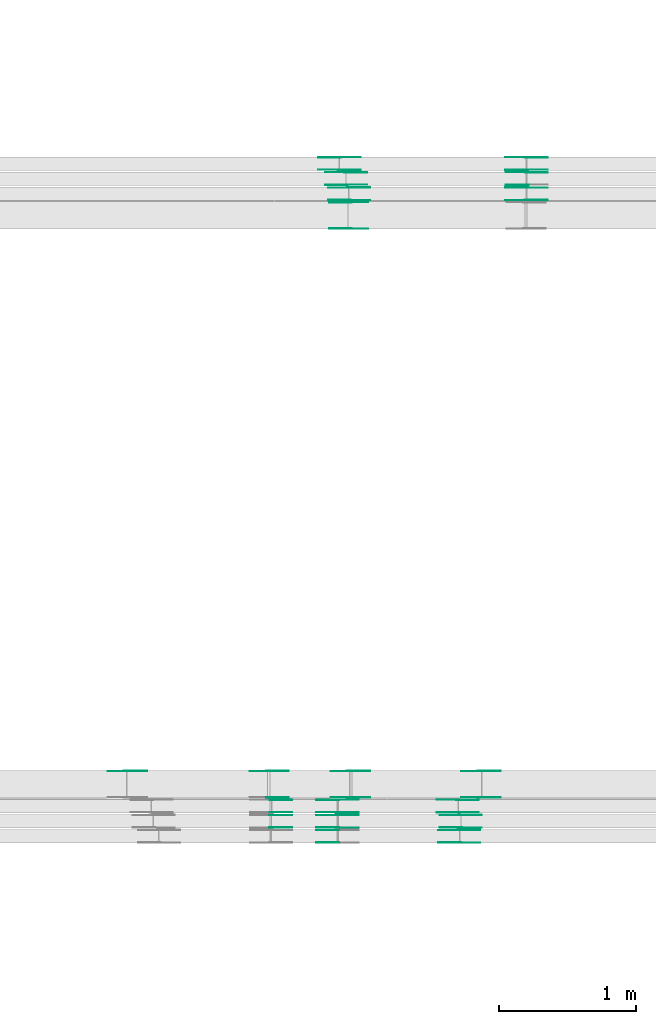
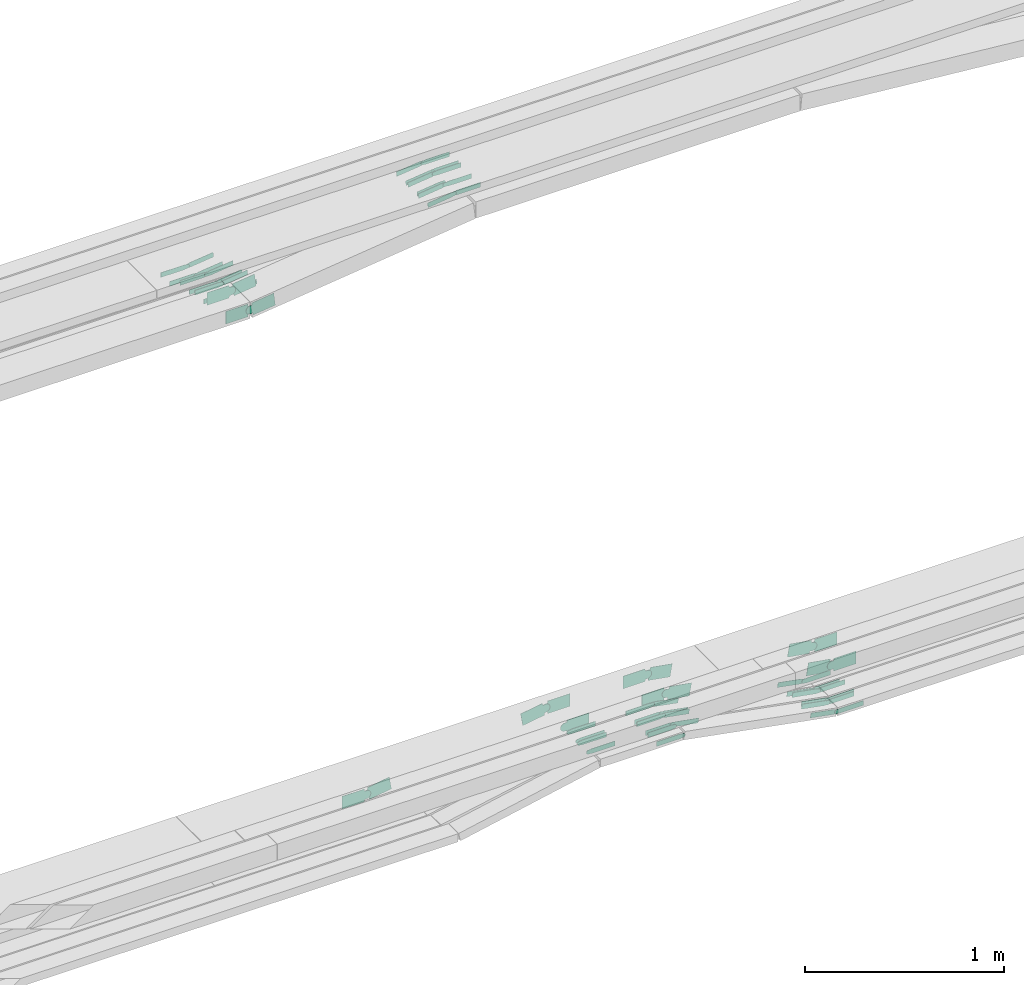
# One storey, part 21 of 32: 66 flow fittings.
"""IFC2X3 building model written with IfcOpenShell, lengths in millimetres."""

from ifc_helpers import new_model, entity, si_unit, converted_unit, derived_unit, direction, frame, frame_2d, origin, place, context, subcontext, project, spatial, polyline, circle_curve, parameter, trimmed, segment, composite_curve, outline, extrude, source, transform, mapped, material, type_object, type_shapes, element, save


model = new_model("IFC2X3")

# Units and contexts
model_context = context("Model", 3, precision=0.01, world=origin(), true_north=direction((6.12303176911189e-17, 1.0)))
body_context = subcontext(model_context, "Body", "Model", "MODEL_VIEW")
ifc_project = project(units=[si_unit("LENGTHUNIT", "METRE", prefix="MILLI"), si_unit("AREAUNIT", "SQUARE_METRE"), si_unit("VOLUMEUNIT", "CUBIC_METRE"), converted_unit("PLANEANGLEUNIT", "DEGREE", entity("IfcRatioMeasure", 0.0174532925199433), si_unit("PLANEANGLEUNIT", "RADIAN"), dimensions=[0, 0, 0, 0, 0, 0, 0]), si_unit("MASSUNIT", "GRAM", prefix="KILO"), derived_unit("MASSDENSITYUNIT", [(si_unit("MASSUNIT", "GRAM", prefix="KILO"), 1), (si_unit("LENGTHUNIT", "METRE"), -3)]), derived_unit("MOMENTOFINERTIAUNIT", [(si_unit("LENGTHUNIT", "METRE"), 4)]), si_unit("TIMEUNIT", "SECOND"), si_unit("FREQUENCYUNIT", "HERTZ"), si_unit("THERMODYNAMICTEMPERATUREUNIT", "DEGREE_CELSIUS"), derived_unit("THERMALTRANSMITTANCEUNIT", [(si_unit("MASSUNIT", "GRAM", prefix="KILO"), 1), (si_unit("THERMODYNAMICTEMPERATUREUNIT", "KELVIN"), -1), (si_unit("TIMEUNIT", "SECOND"), -3)]), derived_unit("VOLUMETRICFLOWRATEUNIT", [(si_unit("LENGTHUNIT", "METRE"), 3), (si_unit("TIMEUNIT", "SECOND"), -1)]), derived_unit("MASSFLOWRATEUNIT", [(si_unit("MASSUNIT", "GRAM", prefix="KILO"), 1), (si_unit("TIMEUNIT", "SECOND"), -1)]), derived_unit("ROTATIONALFREQUENCYUNIT", [(si_unit("TIMEUNIT", "SECOND"), -1)]), si_unit("ELECTRICCURRENTUNIT", "AMPERE"), si_unit("ELECTRICVOLTAGEUNIT", "VOLT"), si_unit("POWERUNIT", "WATT"), si_unit("FORCEUNIT", "NEWTON", prefix="KILO"), si_unit("ILLUMINANCEUNIT", "LUX"), si_unit("LUMINOUSFLUXUNIT", "LUMEN"), si_unit("LUMINOUSINTENSITYUNIT", "CANDELA"), derived_unit("USERDEFINED", [(si_unit("MASSUNIT", "GRAM", prefix="KILO"), -1), (si_unit("LENGTHUNIT", "METRE"), -2), (si_unit("TIMEUNIT", "SECOND"), 3), (si_unit("LUMINOUSFLUXUNIT", "LUMEN"), 1)]), derived_unit("LINEARVELOCITYUNIT", [(si_unit("LENGTHUNIT", "METRE"), 1), (si_unit("TIMEUNIT", "SECOND"), -1)]), si_unit("PRESSUREUNIT", "PASCAL"), derived_unit("USERDEFINED", [(si_unit("LENGTHUNIT", "METRE"), -2), (si_unit("MASSUNIT", "GRAM", prefix="KILO"), 1), (si_unit("TIMEUNIT", "SECOND"), -2)]), derived_unit("LINEARFORCEUNIT", [(si_unit("MASSUNIT", "GRAM", prefix="KILO"), 1), (si_unit("LENGTHUNIT", "METRE"), 1), (si_unit("TIMEUNIT", "SECOND"), -2), (si_unit("LENGTHUNIT", "METRE"), -1)]), derived_unit("PLANARFORCEUNIT", [(si_unit("MASSUNIT", "GRAM", prefix="KILO"), 1), (si_unit("LENGTHUNIT", "METRE"), 1), (si_unit("TIMEUNIT", "SECOND"), -2), (si_unit("LENGTHUNIT", "METRE"), -2)])], contexts=[model_context])

# Site, building, storey
site_placement = place(None, origin())
site = spatial("IfcSite", under=ifc_project, at=site_placement, CompositionType="ELEMENT")
building_placement = place(site_placement, origin())
building = spatial("IfcBuilding", under=site, at=building_placement, CompositionType="ELEMENT")
storey_placement = place(building_placement, frame((0.0, 0.0, 8100.0)))
storey = spatial("IfcBuildingStorey", under=building, at=storey_placement, CompositionType="ELEMENT", Elevation=8100.0)

# Flow fittings
ifc_material = material(Name="G")
cable_carrier_fitting_type_1 = type_object("IfcCableCarrierFittingType", PredefinedType="NOTDEFINED", material=ifc_material)
shared_shape_1 = source(origin(), body_context, "Body", "SweptSolid", [
    extrude(outline(composite_curve([segment(trimmed(circle_curve(frame_2d((-44.59, 0.0), x_axis=(1.0, 0.0)), 12.5), [parameter(90.0000000000007)], [parameter(270.0)], True, "PARAMETER"), True, "CONTINUOUS"), segment(polyline([(-44.59, -12.5), (-33.09, -12.5)]), True, "CONTINUOUS"), segment(polyline([(-33.09, -12.5), (-31.23, -14.5)]), True, "CONTINUOUS"), segment(polyline([(-31.23, -14.5), (108.91, -14.5)]), True, "CONTINUOUS"), segment(polyline([(108.91, -14.5), (108.91, 14.5)]), True, "CONTINUOUS"), segment(polyline([(108.91, 14.5), (-31.23, 14.5)]), True, "CONTINUOUS"), segment(polyline([(-31.23, 14.5), (-33.09, 12.5)]), True, "CONTINUOUS"), segment(polyline([(-33.09, 12.5), (-44.59, 12.5)]), True, "CONTINUOUS")], self_intersect=False)), frame((44.59, 0.0, 0.0), z_axis=(0.0, 0.0, -1.0), x_axis=(1.0, 0.0, 0.0)), (0.0, 0.0, -1.0), 2.0),
])
type_shapes(cable_carrier_fitting_type_1, [shared_shape_1])
for number, where, z_axis, x_axis in (
    (1, (51141.58, 9701.54, 2738.31), (-3.03989319533949e-06, -1.0, -1.63717654735008e-05), (-1.0, 3.03989319574678e-06, 0.0)),
    (2, (50657.45, 9898.46, 2738.54), (0.0, 1.0, 0.0), (1.0, 0.0, 0.0)),
):
    element("IfcFlowFitting", number, at=place(storey_placement, frame(where, z_axis=z_axis, x_axis=x_axis)), inside=storey, type_object=cable_carrier_fitting_type_1, material=ifc_material, context=body_context, shape_type="MappedRepresentation", body=[
        mapped(shared_shape_1, transform((0.0, 0.0, 0.0), scale=1.0)),
    ])
cable_carrier_fitting_type_2 = type_object("IfcCableCarrierFittingType", PredefinedType="NOTDEFINED", material=ifc_material)
type_shapes(cable_carrier_fitting_type_2, [shared_shape_1])
flow_fitting_1_placement = place(storey_placement, frame((51141.24, 9900.46, 2738.54), z_axis=(0.0, 1.0, 0.0), x_axis=(0.983855320382267, 0.0, -0.178965663062798)))
element("IfcFlowFitting", 3, at=flow_fitting_1_placement, inside=storey, type_object=cable_carrier_fitting_type_2, material=ifc_material, context=body_context, shape_type="MappedRepresentation", body=[
    mapped(shared_shape_1, transform((0.0, 0.0, 0.0), scale=1.0)),
])
for number, where, z_axis, x_axis in (
    (4, (51141.24, 9811.54, 2738.54), (0.0, -1.0, 0.0), (-1.0, 0.0, 0.0)),
    (5, (50658.67, 10008.46, 2738.31), (0.0, 1.0, 0.0), (1.0, 0.0, 0.0)),
):
    element("IfcFlowFitting", number, at=place(storey_placement, frame(where, z_axis=z_axis, x_axis=x_axis)), inside=storey, type_object=cable_carrier_fitting_type_1, material=ifc_material, context=body_context, shape_type="MappedRepresentation", body=[
        mapped(shared_shape_1, transform((0.0, 0.0, 0.0), scale=1.0)),
    ])
flow_fitting_2_placement = place(storey_placement, frame((51141.41, 10010.46, 2738.31), z_axis=(0.0, 1.0, 0.0), x_axis=(0.98311633812243, 0.0, -0.182981599393884)))
element("IfcFlowFitting", 6, at=flow_fitting_2_placement, inside=storey, type_object=cable_carrier_fitting_type_2, material=ifc_material, context=body_context, shape_type="MappedRepresentation", body=[
    mapped(shared_shape_1, transform((0.0, 0.0, 0.0), scale=1.0)),
])
flow_fitting_3_placement = place(storey_placement, frame((51141.41, 9921.54, 2738.31), z_axis=(0.0, -1.0, 0.0), x_axis=(-1.0, 0.0, 0.0)))
element("IfcFlowFitting", 7, at=flow_fitting_3_placement, inside=storey, type_object=cable_carrier_fitting_type_1, material=ifc_material, context=body_context, shape_type="MappedRepresentation", body=[
    mapped(shared_shape_1, transform((0.0, 0.0, 0.0), scale=1.0)),
])
flow_fitting_4_placement = place(storey_placement, frame((52019.52, 10010.46, 2574.87), z_axis=(0.0, 1.0, 0.0), x_axis=(-0.98311633812243, 0.0, 0.182981599393884)))
element("IfcFlowFitting", 8, at=flow_fitting_4_placement, inside=storey, type_object=cable_carrier_fitting_type_2, material=ifc_material, context=body_context, shape_type="MappedRepresentation", body=[
    mapped(shared_shape_1, transform((0.0, 0.0, 0.0), scale=1.0)),
])
flow_fitting_5_placement = place(storey_placement, frame((52019.52, 9921.54, 2574.87), z_axis=(0.0, -1.0, 0.0), x_axis=(1.0, 0.0, 0.0)))
element("IfcFlowFitting", 9, at=flow_fitting_5_placement, inside=storey, type_object=cable_carrier_fitting_type_1, material=ifc_material, context=body_context, shape_type="MappedRepresentation", body=[
    mapped(shared_shape_1, transform((0.0, 0.0, 0.0), scale=1.0)),
])
flow_fitting_6_placement = place(storey_placement, frame((51155.5, 14606.82, 2573.87), z_axis=(0.0, -1.0, 0.0), x_axis=(0.993566510793548, 0.0, 0.113250115362128)))
element("IfcFlowFitting", 10, at=flow_fitting_6_placement, inside=storey, type_object=cable_carrier_fitting_type_2, material=ifc_material, context=body_context, shape_type="MappedRepresentation", body=[
    mapped(shared_shape_1, transform((0.0, 0.0, 0.0), scale=1.0)),
])
flow_fitting_7_placement = place(storey_placement, frame((51155.5, 14695.74, 2573.87), z_axis=(0.0, 1.0, 0.0), x_axis=(-1.0, 0.0, 0.0)))
element("IfcFlowFitting", 11, at=flow_fitting_7_placement, inside=storey, type_object=cable_carrier_fitting_type_1, material=ifc_material, context=body_context, shape_type="MappedRepresentation", body=[
    mapped(shared_shape_1, transform((0.0, 0.0, 0.0), scale=1.0)),
])
flow_fitting_8_placement = place(storey_placement, frame((51204.88, 14587.74, 2573.35), z_axis=(0.0, 1.0, 0.0), x_axis=(-1.0, 0.0, 0.0)))
element("IfcFlowFitting", 12, at=flow_fitting_8_placement, inside=storey, type_object=cable_carrier_fitting_type_2, material=ifc_material, context=body_context, shape_type="MappedRepresentation", body=[
    mapped(shared_shape_1, transform((0.0, 0.0, 0.0), scale=1.0)),
])
flow_fitting_9_placement = place(storey_placement, frame((51204.88, 14498.82, 2573.35), z_axis=(0.0, -1.0, 0.0), x_axis=(0.993097003616296, 0.0, 0.117295956487574)))
element("IfcFlowFitting", 13, at=flow_fitting_9_placement, inside=storey, type_object=cable_carrier_fitting_type_1, material=ifc_material, context=body_context, shape_type="MappedRepresentation", body=[
    mapped(shared_shape_1, transform((0.0, 0.0, 0.0), scale=1.0)),
])
flow_fitting_10_placement = place(storey_placement, frame((51226.1, 14386.82, 2573.88), z_axis=(0.0, -1.0, 0.0), x_axis=(0.992897734535639, 0.0, 0.118970957607288)))
element("IfcFlowFitting", 14, at=flow_fitting_10_placement, inside=storey, type_object=cable_carrier_fitting_type_2, material=ifc_material, context=body_context, shape_type="MappedRepresentation", body=[
    mapped(shared_shape_1, transform((0.0, 0.0, 0.0), scale=1.0)),
])
flow_fitting_11_placement = place(storey_placement, frame((51226.1, 14475.74, 2573.88), z_axis=(0.0, 1.0, 0.0), x_axis=(-1.0, 0.0, 0.0)))
element("IfcFlowFitting", 15, at=flow_fitting_11_placement, inside=storey, type_object=cable_carrier_fitting_type_1, material=ifc_material, context=body_context, shape_type="MappedRepresentation", body=[
    mapped(shared_shape_1, transform((0.0, 0.0, 0.0), scale=1.0)),
])
flow_fitting_12_placement = place(storey_placement, frame((52520.91, 14386.82, 2729.03), z_axis=(0.0, -1.0, 0.0), x_axis=(-0.992897734535639, 0.0, -0.118970957607288)))
element("IfcFlowFitting", 16, at=flow_fitting_12_placement, inside=storey, type_object=cable_carrier_fitting_type_2, material=ifc_material, context=body_context, shape_type="MappedRepresentation", body=[
    mapped(shared_shape_1, transform((0.0, 0.0, 0.0), scale=1.0)),
])
flow_fitting_13_placement = place(storey_placement, frame((52520.91, 14475.74, 2729.03), z_axis=(0.0, 1.0, 0.0), x_axis=(1.0, 0.0, 0.0)))
element("IfcFlowFitting", 17, at=flow_fitting_13_placement, inside=storey, type_object=cable_carrier_fitting_type_1, material=ifc_material, context=body_context, shape_type="MappedRepresentation", body=[
    mapped(shared_shape_1, transform((0.0, 0.0, 0.0), scale=1.0)),
])
flow_fitting_14_placement = place(storey_placement, frame((52520.91, 14606.82, 2729.5), z_axis=(0.0, -1.0, 0.0), x_axis=(-0.993566510793548, 0.0, -0.113250115362128)))
element("IfcFlowFitting", 18, at=flow_fitting_14_placement, inside=storey, type_object=cable_carrier_fitting_type_2, material=ifc_material, context=body_context, shape_type="MappedRepresentation", body=[
    mapped(shared_shape_1, transform((0.0, 0.0, 0.0), scale=1.0)),
])
flow_fitting_15_placement = place(storey_placement, frame((52520.91, 14695.74, 2729.5), z_axis=(0.0, 1.0, 0.0), x_axis=(1.0, 0.0, 0.0)))
element("IfcFlowFitting", 19, at=flow_fitting_15_placement, inside=storey, type_object=cable_carrier_fitting_type_1, material=ifc_material, context=body_context, shape_type="MappedRepresentation", body=[
    mapped(shared_shape_1, transform((0.0, 0.0, 0.0), scale=1.0)),
])
flow_fitting_16_placement = place(storey_placement, frame((52522.91, 14496.82, 2729.02), z_axis=(0.0, -1.0, 0.0), x_axis=(-0.993097003616873, 0.0, -0.117295956482691)))
element("IfcFlowFitting", 20, at=flow_fitting_16_placement, inside=storey, type_object=cable_carrier_fitting_type_2, material=ifc_material, context=body_context, shape_type="MappedRepresentation", body=[
    mapped(shared_shape_1, transform((0.0, 0.0, 0.0), scale=1.0)),
])
flow_fitting_17_placement = place(storey_placement, frame((52522.91, 14585.74, 2729.02), z_axis=(0.0, 1.0, 0.0), x_axis=(1.0, 0.0, 0.0)))
element("IfcFlowFitting", 21, at=flow_fitting_17_placement, inside=storey, type_object=cable_carrier_fitting_type_1, material=ifc_material, context=body_context, shape_type="MappedRepresentation", body=[
    mapped(shared_shape_1, transform((0.0, 0.0, 0.0), scale=1.0)),
])
flow_fitting_18_placement = place(storey_placement, frame((52040.11, 9809.54, 2575.03), z_axis=(0.0, -1.0, 0.0), x_axis=(1.0, 0.0, -5.61945698194788e-05)))
element("IfcFlowFitting", 22, at=flow_fitting_18_placement, inside=storey, type_object=cable_carrier_fitting_type_2, material=ifc_material, context=body_context, shape_type="MappedRepresentation", body=[
    mapped(shared_shape_1, transform((0.0, 0.0, 0.0), scale=1.0)),
])
flow_fitting_19_placement = place(storey_placement, frame((52040.11, 9898.46, 2575.03), z_axis=(0.0, 1.0, 0.0), x_axis=(-0.983855320382267, 0.0, 0.178965663062799)))
element("IfcFlowFitting", 23, at=flow_fitting_19_placement, inside=storey, type_object=cable_carrier_fitting_type_1, material=ifc_material, context=body_context, shape_type="MappedRepresentation", body=[
    mapped(shared_shape_1, transform((0.0, 0.0, 0.0), scale=1.0)),
])
flow_fitting_20_placement = place(storey_placement, frame((52030.11, 9699.54, 2573.33), z_axis=(0.0, -1.0, 0.0), x_axis=(1.0, 0.0, -5.86021096785072e-05)))
element("IfcFlowFitting", 24, at=flow_fitting_20_placement, inside=storey, type_object=cable_carrier_fitting_type_2, material=ifc_material, context=body_context, shape_type="MappedRepresentation", body=[
    mapped(shared_shape_1, transform((0.0, 0.0, 0.0), scale=1.0)),
])
flow_fitting_21_placement = place(storey_placement, frame((52030.11, 9788.46, 2573.33), z_axis=(0.0, 1.0, 0.0), x_axis=(-0.983194962125338, 0.0, 0.182558665779952)))
element("IfcFlowFitting", 25, at=flow_fitting_21_placement, inside=storey, type_object=cable_carrier_fitting_type_1, material=ifc_material, context=body_context, shape_type="MappedRepresentation", body=[
    mapped(shared_shape_1, transform((0.0, 0.0, 0.0), scale=1.0)),
])
cable_carrier_fitting_type_3 = type_object("IfcCableCarrierFittingType", PredefinedType="NOTDEFINED", material=ifc_material)
shared_shape_2 = source(origin(), body_context, "Body", "SweptSolid", [
    extrude(outline(composite_curve([segment(trimmed(circle_curve(frame_2d((-44.59, 0.0), x_axis=(1.0, 0.0)), 12.5), [parameter(90.0000000000007)], [parameter(270.0)], True, "PARAMETER"), True, "CONTINUOUS"), segment(polyline([(-44.59, -12.5), (-33.09, -12.5)]), True, "CONTINUOUS"), segment(polyline([(-33.09, -12.5), (-31.23, -14.5)]), True, "CONTINUOUS"), segment(polyline([(-31.23, -14.5), (108.91, -14.5)]), True, "CONTINUOUS"), segment(polyline([(108.91, -14.5), (108.91, 14.5)]), True, "CONTINUOUS"), segment(polyline([(108.91, 14.5), (-31.23, 14.5)]), True, "CONTINUOUS"), segment(polyline([(-31.23, 14.5), (-33.09, 12.5)]), True, "CONTINUOUS"), segment(polyline([(-33.09, 12.5), (-44.59, 12.5)]), True, "CONTINUOUS")], self_intersect=False)), frame((44.59, 0.0, 0.0)), (0.0, 0.0, 1.0), 2.0),
])
type_shapes(cable_carrier_fitting_type_3, [shared_shape_2])
for number, where, z_axis, x_axis in (
    (26, (51141.58, 9788.46, 2738.31), (3.03989316820429e-06, 1.0, 1.63717654870684e-05), (-1.0, 3.03989316861159e-06, 0.0)),
    (27, (50657.45, 9811.54, 2738.54), (0.0, -1.0, 0.0), (1.0, 0.0, 0.0)),
):
    element("IfcFlowFitting", number, at=place(storey_placement, frame(where, z_axis=z_axis, x_axis=x_axis)), inside=storey, type_object=cable_carrier_fitting_type_3, material=ifc_material, context=body_context, shape_type="MappedRepresentation", body=[
        mapped(shared_shape_2, transform((0.0, 0.0, 0.0), scale=1.0)),
    ])
cable_carrier_fitting_type_4 = type_object("IfcCableCarrierFittingType", PredefinedType="NOTDEFINED", material=ifc_material)
type_shapes(cable_carrier_fitting_type_4, [shared_shape_2])
flow_fitting_22_placement = place(storey_placement, frame((51141.24, 9809.54, 2738.54), z_axis=(0.0, -1.0, 0.0), x_axis=(0.983855320382267, 0.0, -0.178965663062798)))
element("IfcFlowFitting", 28, at=flow_fitting_22_placement, inside=storey, type_object=cable_carrier_fitting_type_4, material=ifc_material, context=body_context, shape_type="MappedRepresentation", body=[
    mapped(shared_shape_2, transform((0.0, 0.0, 0.0), scale=1.0)),
])
for number, where, z_axis, x_axis in (
    (29, (51141.24, 9898.46, 2738.54), (0.0, 1.0, 0.0), (-1.0, 0.0, 0.0)),
    (30, (50658.67, 9921.54, 2738.31), (0.0, -1.0, 0.0), (1.0, 0.0, 0.0)),
):
    element("IfcFlowFitting", number, at=place(storey_placement, frame(where, z_axis=z_axis, x_axis=x_axis)), inside=storey, type_object=cable_carrier_fitting_type_3, material=ifc_material, context=body_context, shape_type="MappedRepresentation", body=[
        mapped(shared_shape_2, transform((0.0, 0.0, 0.0), scale=1.0)),
    ])
flow_fitting_23_placement = place(storey_placement, frame((51141.41, 9919.54, 2738.31), z_axis=(0.0, -1.0, 0.0), x_axis=(0.98311633812243, 0.0, -0.182981599393884)))
element("IfcFlowFitting", 31, at=flow_fitting_23_placement, inside=storey, type_object=cable_carrier_fitting_type_4, material=ifc_material, context=body_context, shape_type="MappedRepresentation", body=[
    mapped(shared_shape_2, transform((0.0, 0.0, 0.0), scale=1.0)),
])
flow_fitting_24_placement = place(storey_placement, frame((51141.41, 10008.46, 2738.31), z_axis=(0.0, 1.0, 0.0), x_axis=(-1.0, 0.0, 0.0)))
element("IfcFlowFitting", 32, at=flow_fitting_24_placement, inside=storey, type_object=cable_carrier_fitting_type_3, material=ifc_material, context=body_context, shape_type="MappedRepresentation", body=[
    mapped(shared_shape_2, transform((0.0, 0.0, 0.0), scale=1.0)),
])
flow_fitting_25_placement = place(storey_placement, frame((52019.52, 9919.54, 2574.87), z_axis=(0.0, -1.0, 0.0), x_axis=(-0.98311633812243, 0.0, 0.182981599393884)))
element("IfcFlowFitting", 33, at=flow_fitting_25_placement, inside=storey, type_object=cable_carrier_fitting_type_4, material=ifc_material, context=body_context, shape_type="MappedRepresentation", body=[
    mapped(shared_shape_2, transform((0.0, 0.0, 0.0), scale=1.0)),
])
flow_fitting_26_placement = place(storey_placement, frame((52019.52, 10008.46, 2574.87), z_axis=(0.0, 1.0, 0.0), x_axis=(1.0, 0.0, 0.0)))
element("IfcFlowFitting", 34, at=flow_fitting_26_placement, inside=storey, type_object=cable_carrier_fitting_type_3, material=ifc_material, context=body_context, shape_type="MappedRepresentation", body=[
    mapped(shared_shape_2, transform((0.0, 0.0, 0.0), scale=1.0)),
])
flow_fitting_27_placement = place(storey_placement, frame((51155.5, 14697.74, 2573.87), z_axis=(0.0, 1.0, 0.0), x_axis=(0.993566510793548, 0.0, 0.113250115362128)))
element("IfcFlowFitting", 35, at=flow_fitting_27_placement, inside=storey, type_object=cable_carrier_fitting_type_4, material=ifc_material, context=body_context, shape_type="MappedRepresentation", body=[
    mapped(shared_shape_2, transform((0.0, 0.0, 0.0), scale=1.0)),
])
flow_fitting_28_placement = place(storey_placement, frame((51155.5, 14608.82, 2573.87), z_axis=(0.0, -1.0, 0.0), x_axis=(-1.0, 0.0, 0.0)))
element("IfcFlowFitting", 36, at=flow_fitting_28_placement, inside=storey, type_object=cable_carrier_fitting_type_3, material=ifc_material, context=body_context, shape_type="MappedRepresentation", body=[
    mapped(shared_shape_2, transform((0.0, 0.0, 0.0), scale=1.0)),
])
flow_fitting_29_placement = place(storey_placement, frame((51204.88, 14496.82, 2573.35), z_axis=(0.0, -1.0, 0.0), x_axis=(-1.0, 0.0, 0.0)))
element("IfcFlowFitting", 37, at=flow_fitting_29_placement, inside=storey, type_object=cable_carrier_fitting_type_4, material=ifc_material, context=body_context, shape_type="MappedRepresentation", body=[
    mapped(shared_shape_2, transform((0.0, 0.0, 0.0), scale=1.0)),
])
flow_fitting_30_placement = place(storey_placement, frame((51204.88, 14585.74, 2573.35), z_axis=(0.0, 1.0, 0.0), x_axis=(0.993097003616296, 0.0, 0.117295956487574)))
element("IfcFlowFitting", 38, at=flow_fitting_30_placement, inside=storey, type_object=cable_carrier_fitting_type_3, material=ifc_material, context=body_context, shape_type="MappedRepresentation", body=[
    mapped(shared_shape_2, transform((0.0, 0.0, 0.0), scale=1.0)),
])
flow_fitting_31_placement = place(storey_placement, frame((51226.1, 14477.74, 2573.88), z_axis=(0.0, 1.0, 0.0), x_axis=(0.992897734535639, 0.0, 0.118970957607288)))
element("IfcFlowFitting", 39, at=flow_fitting_31_placement, inside=storey, type_object=cable_carrier_fitting_type_4, material=ifc_material, context=body_context, shape_type="MappedRepresentation", body=[
    mapped(shared_shape_2, transform((0.0, 0.0, 0.0), scale=1.0)),
])
flow_fitting_32_placement = place(storey_placement, frame((51226.1, 14388.82, 2573.88), z_axis=(0.0, -1.0, 0.0), x_axis=(-1.0, 0.0, 0.0)))
element("IfcFlowFitting", 40, at=flow_fitting_32_placement, inside=storey, type_object=cable_carrier_fitting_type_3, material=ifc_material, context=body_context, shape_type="MappedRepresentation", body=[
    mapped(shared_shape_2, transform((0.0, 0.0, 0.0), scale=1.0)),
])
flow_fitting_33_placement = place(storey_placement, frame((52520.91, 14477.74, 2729.03), z_axis=(0.0, 1.0, 0.0), x_axis=(-0.992897734535639, 0.0, -0.118970957607288)))
element("IfcFlowFitting", 41, at=flow_fitting_33_placement, inside=storey, type_object=cable_carrier_fitting_type_4, material=ifc_material, context=body_context, shape_type="MappedRepresentation", body=[
    mapped(shared_shape_2, transform((0.0, 0.0, 0.0), scale=1.0)),
])
flow_fitting_34_placement = place(storey_placement, frame((52520.91, 14388.82, 2729.03), z_axis=(0.0, -1.0, 0.0), x_axis=(1.0, 0.0, 0.0)))
element("IfcFlowFitting", 42, at=flow_fitting_34_placement, inside=storey, type_object=cable_carrier_fitting_type_3, material=ifc_material, context=body_context, shape_type="MappedRepresentation", body=[
    mapped(shared_shape_2, transform((0.0, 0.0, 0.0), scale=1.0)),
])
flow_fitting_35_placement = place(storey_placement, frame((52520.91, 14697.74, 2729.5), z_axis=(0.0, 1.0, 0.0), x_axis=(-0.993566510793548, 0.0, -0.113250115362128)))
element("IfcFlowFitting", 43, at=flow_fitting_35_placement, inside=storey, type_object=cable_carrier_fitting_type_4, material=ifc_material, context=body_context, shape_type="MappedRepresentation", body=[
    mapped(shared_shape_2, transform((0.0, 0.0, 0.0), scale=1.0)),
])
flow_fitting_36_placement = place(storey_placement, frame((52520.91, 14608.82, 2729.5), z_axis=(0.0, -1.0, 0.0), x_axis=(1.0, 0.0, 0.0)))
element("IfcFlowFitting", 44, at=flow_fitting_36_placement, inside=storey, type_object=cable_carrier_fitting_type_3, material=ifc_material, context=body_context, shape_type="MappedRepresentation", body=[
    mapped(shared_shape_2, transform((0.0, 0.0, 0.0), scale=1.0)),
])
for number, where, z_axis, x_axis in (
    (45, (52522.91, 14587.74, 2729.02), (0.0, 1.0, 0.0), (-0.993097003616873, 0.0, -0.117295956482691)),
    (46, (52040.11, 9900.46, 2575.03), (0.0, 1.0, 0.0), (1.0, 0.0, -5.61945698194788e-05)),
):
    element("IfcFlowFitting", number, at=place(storey_placement, frame(where, z_axis=z_axis, x_axis=x_axis)), inside=storey, type_object=cable_carrier_fitting_type_4, material=ifc_material, context=body_context, shape_type="MappedRepresentation", body=[
        mapped(shared_shape_2, transform((0.0, 0.0, 0.0), scale=1.0)),
    ])
flow_fitting_37_placement = place(storey_placement, frame((52040.11, 9811.54, 2575.03), z_axis=(0.0, -1.0, 0.0), x_axis=(-0.983855320382267, 0.0, 0.178965663062799)))
element("IfcFlowFitting", 47, at=flow_fitting_37_placement, inside=storey, type_object=cable_carrier_fitting_type_3, material=ifc_material, context=body_context, shape_type="MappedRepresentation", body=[
    mapped(shared_shape_2, transform((0.0, 0.0, 0.0), scale=1.0)),
])
flow_fitting_38_placement = place(storey_placement, frame((52030.11, 9790.46, 2573.33), z_axis=(0.0, 1.0, 0.0), x_axis=(1.0, 0.0, -5.86021096785072e-05)))
element("IfcFlowFitting", 48, at=flow_fitting_38_placement, inside=storey, type_object=cable_carrier_fitting_type_4, material=ifc_material, context=body_context, shape_type="MappedRepresentation", body=[
    mapped(shared_shape_2, transform((0.0, 0.0, 0.0), scale=1.0)),
])
flow_fitting_39_placement = place(storey_placement, frame((52030.11, 9701.54, 2573.33), z_axis=(0.0, -1.0, 0.0), x_axis=(-0.983194962125338, 0.0, 0.182558665779952)))
element("IfcFlowFitting", 49, at=flow_fitting_39_placement, inside=storey, type_object=cable_carrier_fitting_type_3, material=ifc_material, context=body_context, shape_type="MappedRepresentation", body=[
    mapped(shared_shape_2, transform((0.0, 0.0, 0.0), scale=1.0)),
])
cable_carrier_fitting_type_5 = type_object("IfcCableCarrierFittingType", PredefinedType="NOTDEFINED", material=ifc_material)
shared_shape_3 = source(origin(), body_context, "Body", "SweptSolid", [
    extrude(outline(composite_curve([segment(trimmed(circle_curve(frame_2d((-41.47, 0.0), x_axis=(1.0, 0.0)), 25.0), [parameter(90.0000000000007)], [parameter(270.0)], True, "PARAMETER"), True, "CONTINUOUS"), segment(polyline([(-41.47, -25.0), (-29.97, -25.0)]), True, "CONTINUOUS"), segment(polyline([(-29.97, -25.0), (-28.1, -38.5)]), True, "CONTINUOUS"), segment(polyline([(-28.1, -38.5), (99.53, -38.5)]), True, "CONTINUOUS"), segment(polyline([(99.53, -38.5), (99.53, 38.5)]), True, "CONTINUOUS"), segment(polyline([(99.53, 38.5), (-28.1, 38.5)]), True, "CONTINUOUS"), segment(polyline([(-28.1, 38.5), (-29.97, 25.0)]), True, "CONTINUOUS"), segment(polyline([(-29.97, 25.0), (-41.47, 25.0)]), True, "CONTINUOUS")], self_intersect=False)), frame((41.47, 0.0, 0.0), z_axis=(0.0, 0.0, -1.0), x_axis=(1.0, 0.0, 0.0)), (0.0, 0.0, -1.0), 2.0),
])
type_shapes(cable_carrier_fitting_type_5, [shared_shape_3])
flow_fitting_40_placement = place(storey_placement, frame((49608.28, 10218.46, 2597.39), z_axis=(0.0, 1.0, 0.0), x_axis=(-1.0, 0.0, 0.0)))
element("IfcFlowFitting", 50, at=flow_fitting_40_placement, inside=storey, type_object=cable_carrier_fitting_type_5, material=ifc_material, context=body_context, shape_type="MappedRepresentation", body=[
    mapped(shared_shape_3, transform((0.0, 0.0, 0.0), scale=1.0)),
])
cable_carrier_fitting_type_6 = type_object("IfcCableCarrierFittingType", PredefinedType="NOTDEFINED", material=ifc_material)
type_shapes(cable_carrier_fitting_type_6, [shared_shape_3])
for number, where, z_axis, x_axis in (
    (51, (50645.66, 10220.46, 2763.61), (0.0, 1.0, 0.0), (1.0, 0.0, 0.0)),
    (52, (51233.98, 10220.46, 2763.61), (0.0, 1.0, 0.0), (0.985679085688948, 0.0, -0.168631966232386)),
):
    element("IfcFlowFitting", number, at=place(storey_placement, frame(where, z_axis=z_axis, x_axis=x_axis)), inside=storey, type_object=cable_carrier_fitting_type_6, material=ifc_material, context=body_context, shape_type="MappedRepresentation", body=[
        mapped(shared_shape_3, transform((0.0, 0.0, 0.0), scale=1.0)),
    ])
flow_fitting_41_placement = place(storey_placement, frame((51233.98, 10031.54, 2763.61), z_axis=(0.0, -1.0, 0.0), x_axis=(-1.0, 0.0, 0.0)))
element("IfcFlowFitting", 53, at=flow_fitting_41_placement, inside=storey, type_object=cable_carrier_fitting_type_5, material=ifc_material, context=body_context, shape_type="MappedRepresentation", body=[
    mapped(shared_shape_3, transform((0.0, 0.0, 0.0), scale=1.0)),
])
flow_fitting_42_placement = place(storey_placement, frame((51221.47, 14179.04, 2598.88), z_axis=(0.0, -1.0, 0.0), x_axis=(0.992897734535631, 0.0, 0.118970957607356)))
element("IfcFlowFitting", 54, at=flow_fitting_42_placement, inside=storey, type_object=cable_carrier_fitting_type_6, material=ifc_material, context=body_context, shape_type="MappedRepresentation", body=[
    mapped(shared_shape_3, transform((0.0, 0.0, 0.0), scale=1.0)),
])
flow_fitting_43_placement = place(storey_placement, frame((51221.47, 14367.96, 2598.88), z_axis=(0.0, 1.0, 0.0), x_axis=(-1.0, 0.0, 0.0)))
element("IfcFlowFitting", 55, at=flow_fitting_43_placement, inside=storey, type_object=cable_carrier_fitting_type_5, material=ifc_material, context=body_context, shape_type="MappedRepresentation", body=[
    mapped(shared_shape_3, transform((0.0, 0.0, 0.0), scale=1.0)),
])
flow_fitting_44_placement = place(storey_placement, frame((52190.11, 10029.54, 2600.03), z_axis=(0.0, -1.0, 0.0), x_axis=(0.999999997952967, 0.0, -6.39848897058259e-05)))
element("IfcFlowFitting", 56, at=flow_fitting_44_placement, inside=storey, type_object=cable_carrier_fitting_type_6, material=ifc_material, context=body_context, shape_type="MappedRepresentation", body=[
    mapped(shared_shape_3, transform((0.0, 0.0, 0.0), scale=1.0)),
])
flow_fitting_45_placement = place(storey_placement, frame((52190.11, 10218.46, 2600.03), z_axis=(0.0, 1.0, 0.0), x_axis=(-0.985679085688951, 0.0, 0.168631966232368)))
element("IfcFlowFitting", 57, at=flow_fitting_45_placement, inside=storey, type_object=cable_carrier_fitting_type_5, material=ifc_material, context=body_context, shape_type="MappedRepresentation", body=[
    mapped(shared_shape_3, transform((0.0, 0.0, 0.0), scale=1.0)),
])
cable_carrier_fitting_type_7 = type_object("IfcCableCarrierFittingType", PredefinedType="NOTDEFINED", material=ifc_material)
shared_shape_4 = source(origin(), body_context, "Body", "SweptSolid", [
    extrude(outline(composite_curve([segment(trimmed(circle_curve(frame_2d((-41.47, 0.0), x_axis=(1.0, 0.0)), 25.0), [parameter(90.0000000000007)], [parameter(270.0)], True, "PARAMETER"), True, "CONTINUOUS"), segment(polyline([(-41.47, -25.0), (-29.97, -25.0)]), True, "CONTINUOUS"), segment(polyline([(-29.97, -25.0), (-28.1, -38.5)]), True, "CONTINUOUS"), segment(polyline([(-28.1, -38.5), (99.53, -38.5)]), True, "CONTINUOUS"), segment(polyline([(99.53, -38.5), (99.53, 38.5)]), True, "CONTINUOUS"), segment(polyline([(99.53, 38.5), (-28.1, 38.5)]), True, "CONTINUOUS"), segment(polyline([(-28.1, 38.5), (-29.97, 25.0)]), True, "CONTINUOUS"), segment(polyline([(-29.97, 25.0), (-41.47, 25.0)]), True, "CONTINUOUS")], self_intersect=False)), frame((41.47, 0.0, 0.0)), (0.0, 0.0, 1.0), 2.0),
])
type_shapes(cable_carrier_fitting_type_7, [shared_shape_4])
for number, where, z_axis, x_axis in (
    (58, (49608.28, 10220.46, 2597.39), (0.0, 1.0, 0.0), (0.987405642693208, 0.0, 0.15820902874872)),
    (59, (50645.66, 10029.54, 2763.61), (0.0, -1.0, 0.0), (1.0, 0.0, 0.0)),
):
    element("IfcFlowFitting", number, at=place(storey_placement, frame(where, z_axis=z_axis, x_axis=x_axis)), inside=storey, type_object=cable_carrier_fitting_type_7, material=ifc_material, context=body_context, shape_type="MappedRepresentation", body=[
        mapped(shared_shape_4, transform((0.0, 0.0, 0.0), scale=1.0)),
    ])
cable_carrier_fitting_type_8 = type_object("IfcCableCarrierFittingType", PredefinedType="NOTDEFINED", material=ifc_material)
type_shapes(cable_carrier_fitting_type_8, [shared_shape_4])
flow_fitting_46_placement = place(storey_placement, frame((50645.66, 10218.46, 2763.61), z_axis=(0.0, 1.0, 0.0), x_axis=(-0.987405642693216, 0.0, -0.158209028748672)))
element("IfcFlowFitting", 60, at=flow_fitting_46_placement, inside=storey, type_object=cable_carrier_fitting_type_8, material=ifc_material, context=body_context, shape_type="MappedRepresentation", body=[
    mapped(shared_shape_4, transform((0.0, 0.0, 0.0), scale=1.0)),
])
flow_fitting_47_placement = place(storey_placement, frame((51233.98, 10029.54, 2763.61), z_axis=(0.0, -1.0, 0.0), x_axis=(0.985679085688948, 0.0, -0.168631966232386)))
element("IfcFlowFitting", 61, at=flow_fitting_47_placement, inside=storey, type_object=cable_carrier_fitting_type_7, material=ifc_material, context=body_context, shape_type="MappedRepresentation", body=[
    mapped(shared_shape_4, transform((0.0, 0.0, 0.0), scale=1.0)),
])
flow_fitting_48_placement = place(storey_placement, frame((51233.98, 10218.46, 2763.61), z_axis=(0.0, 1.0, 0.0), x_axis=(-1.0, 0.0, 0.0)))
element("IfcFlowFitting", 62, at=flow_fitting_48_placement, inside=storey, type_object=cable_carrier_fitting_type_8, material=ifc_material, context=body_context, shape_type="MappedRepresentation", body=[
    mapped(shared_shape_4, transform((0.0, 0.0, 0.0), scale=1.0)),
])
flow_fitting_49_placement = place(storey_placement, frame((51221.47, 14369.96, 2598.88), z_axis=(0.0, 1.0, 0.0), x_axis=(0.992897734535631, 0.0, 0.118970957607356)))
element("IfcFlowFitting", 63, at=flow_fitting_49_placement, inside=storey, type_object=cable_carrier_fitting_type_7, material=ifc_material, context=body_context, shape_type="MappedRepresentation", body=[
    mapped(shared_shape_4, transform((0.0, 0.0, 0.0), scale=1.0)),
])
flow_fitting_50_placement = place(storey_placement, frame((51221.47, 14181.04, 2598.88), z_axis=(0.0, -1.0, 0.0), x_axis=(-1.0, 0.0, 0.0)))
element("IfcFlowFitting", 64, at=flow_fitting_50_placement, inside=storey, type_object=cable_carrier_fitting_type_8, material=ifc_material, context=body_context, shape_type="MappedRepresentation", body=[
    mapped(shared_shape_4, transform((0.0, 0.0, 0.0), scale=1.0)),
])
flow_fitting_51_placement = place(storey_placement, frame((52190.11, 10220.46, 2600.03), z_axis=(0.0, 1.0, 0.0), x_axis=(0.999999997952967, 0.0, -6.39848897058259e-05)))
element("IfcFlowFitting", 65, at=flow_fitting_51_placement, inside=storey, type_object=cable_carrier_fitting_type_7, material=ifc_material, context=body_context, shape_type="MappedRepresentation", body=[
    mapped(shared_shape_4, transform((0.0, 0.0, 0.0), scale=1.0)),
])
flow_fitting_52_placement = place(storey_placement, frame((52190.11, 10031.54, 2600.03), z_axis=(0.0, -1.0, 0.0), x_axis=(-0.985679085688951, 0.0, 0.168631966232368)))
element("IfcFlowFitting", 66, at=flow_fitting_52_placement, inside=storey, type_object=cable_carrier_fitting_type_8, material=ifc_material, context=body_context, shape_type="MappedRepresentation", body=[
    mapped(shared_shape_4, transform((0.0, 0.0, 0.0), scale=1.0)),
])

save(model, "model.ifc")
